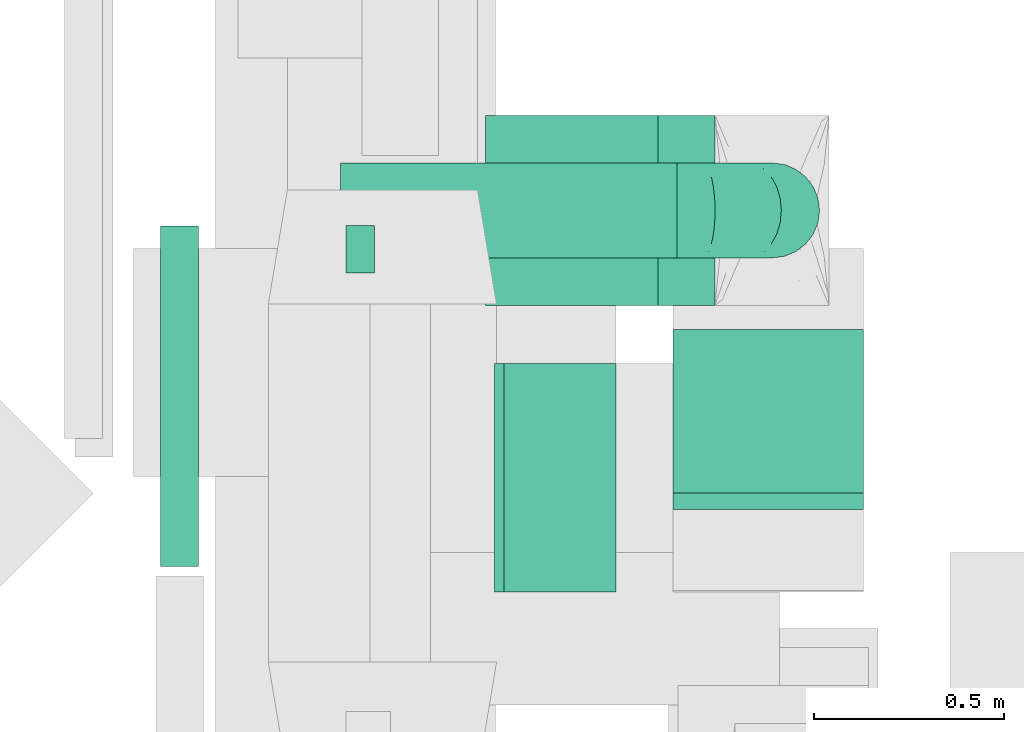
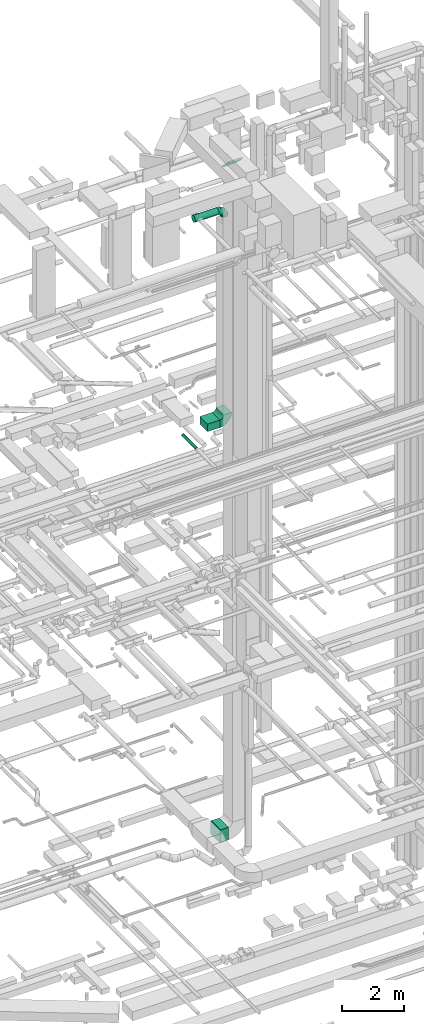
# One storey, part 133 of 337: 6 flow segments, 3 flow fittings.
"""IFC2X3 building model written with IfcOpenShell, lengths in millimetres."""

from ifc_helpers import new_model, entity, si_unit, converted_unit, derived_unit, direction, frame, frame_2d, origin, origin_2d_with_axis, place, context, subcontext, project, spatial, polyline, circle_curve, parameter, trimmed, segment, composite_curve, rectangle, circle, outline, extrude, faceted_brep, source, transform, mapped, material, type_object, type_shapes, element, save


model = new_model("IFC2X3")

# Units and contexts
model_context = context("Model", 3, precision=0.01, world=origin(), true_north=direction((6.12303176911189e-17, 1.0)))
body_context = subcontext(model_context, "Body", "Model", "MODEL_VIEW")
ifc_project = project(units=[si_unit("LENGTHUNIT", "METRE", prefix="MILLI"), si_unit("AREAUNIT", "SQUARE_METRE"), si_unit("VOLUMEUNIT", "CUBIC_METRE"), converted_unit("PLANEANGLEUNIT", "DEGREE", entity("IfcRatioMeasure", 0.0174532925199433), si_unit("PLANEANGLEUNIT", "RADIAN"), dimensions=[0, 0, 0, 0, 0, 0, 0]), si_unit("MASSUNIT", "GRAM", prefix="KILO"), derived_unit("MASSDENSITYUNIT", [(si_unit("MASSUNIT", "GRAM", prefix="KILO"), 1), (si_unit("LENGTHUNIT", "METRE"), -3)]), derived_unit("MOMENTOFINERTIAUNIT", [(si_unit("LENGTHUNIT", "METRE"), 4)]), si_unit("TIMEUNIT", "SECOND"), si_unit("FREQUENCYUNIT", "HERTZ"), si_unit("THERMODYNAMICTEMPERATUREUNIT", "DEGREE_CELSIUS"), derived_unit("THERMALTRANSMITTANCEUNIT", [(si_unit("MASSUNIT", "GRAM", prefix="KILO"), 1), (si_unit("THERMODYNAMICTEMPERATUREUNIT", "KELVIN"), -1), (si_unit("TIMEUNIT", "SECOND"), -3)]), derived_unit("VOLUMETRICFLOWRATEUNIT", [(si_unit("LENGTHUNIT", "METRE"), 3), (si_unit("TIMEUNIT", "SECOND"), -1)]), derived_unit("MASSFLOWRATEUNIT", [(si_unit("MASSUNIT", "GRAM", prefix="KILO"), 1), (si_unit("TIMEUNIT", "SECOND"), -1)]), derived_unit("ROTATIONALFREQUENCYUNIT", [(si_unit("TIMEUNIT", "SECOND"), -1)]), si_unit("ELECTRICCURRENTUNIT", "AMPERE"), si_unit("ELECTRICVOLTAGEUNIT", "VOLT"), si_unit("POWERUNIT", "WATT"), si_unit("FORCEUNIT", "NEWTON", prefix="KILO"), si_unit("ILLUMINANCEUNIT", "LUX"), si_unit("LUMINOUSFLUXUNIT", "LUMEN"), si_unit("LUMINOUSINTENSITYUNIT", "CANDELA"), derived_unit("USERDEFINED", [(si_unit("MASSUNIT", "GRAM", prefix="KILO"), -1), (si_unit("LENGTHUNIT", "METRE"), -2), (si_unit("TIMEUNIT", "SECOND"), 3), (si_unit("LUMINOUSFLUXUNIT", "LUMEN"), 1)]), derived_unit("LINEARVELOCITYUNIT", [(si_unit("LENGTHUNIT", "METRE"), 1), (si_unit("TIMEUNIT", "SECOND"), -1)]), si_unit("PRESSUREUNIT", "PASCAL"), derived_unit("USERDEFINED", [(si_unit("LENGTHUNIT", "METRE"), -2), (si_unit("MASSUNIT", "GRAM", prefix="KILO"), 1), (si_unit("TIMEUNIT", "SECOND"), -2)]), derived_unit("LINEARFORCEUNIT", [(si_unit("MASSUNIT", "GRAM", prefix="KILO"), 1), (si_unit("LENGTHUNIT", "METRE"), 1), (si_unit("TIMEUNIT", "SECOND"), -2), (si_unit("LENGTHUNIT", "METRE"), -1)]), derived_unit("PLANARFORCEUNIT", [(si_unit("MASSUNIT", "GRAM", prefix="KILO"), 1), (si_unit("LENGTHUNIT", "METRE"), 1), (si_unit("TIMEUNIT", "SECOND"), -2), (si_unit("LENGTHUNIT", "METRE"), -2)])], contexts=[model_context])

# Site, building, storey
site_placement = place(None, origin())
site = spatial("IfcSite", under=ifc_project, at=site_placement, CompositionType="ELEMENT")
building_placement = place(site_placement, origin())
building = spatial("IfcBuilding", under=site, at=building_placement, CompositionType="ELEMENT")
storey_placement = place(building_placement, origin())
storey = spatial("IfcBuildingStorey", under=building, at=storey_placement, CompositionType="ELEMENT", Elevation=0.0)

# Flow segments
duct_segment_type_1 = type_object("IfcDuctSegmentType", PredefinedType="NOTDEFINED")
flow_segment_1_placement = place(storey_placement, frame((23635.55, 11795.95, 3200.0)))
element("IfcFlowSegment", 1, at=flow_segment_1_placement, inside=storey, type_object=duct_segment_type_1, context=body_context, shape_type="SweptSolid", body=[
    extrude(rectangle(XDim=293.750000000011, YDim=600.0, at=origin_2d_with_axis()), frame((146.88, 300.0, 0.0)), (0.0, 0.0, 1.0), 500.0),
])
flow_segment_2_placement = place(storey_placement, frame((23586.61, 12547.9, 18950.0)))
element("IfcFlowSegment", 2, at=flow_segment_2_placement, inside=storey, type_object=duct_segment_type_1, context=body_context, shape_type="SweptSolid", body=[
    extrude(rectangle(XDim=452.500000000023, YDim=499.999999999999, at=origin_2d_with_axis()), frame((226.25, 250.0, 0.0)), (0.0, 0.0, 1.0), 300.000000000001),
])
duct_segment_type_2 = type_object("IfcDuctSegmentType", PredefinedType="NOTDEFINED")
flow_segment_3_placement = place(storey_placement, frame((22730.99, 11862.12, 18933.4)))
element("IfcFlowSegment", 3, at=flow_segment_3_placement, inside=storey, type_object=duct_segment_type_2, context=body_context, shape_type="SweptSolid", body=[
    extrude(circle(Radius=50.0, at=origin_2d_with_axis()), frame((51.6, 0.0, 51.6), z_axis=(0.0, 1.0, 0.0), x_axis=(1.0, 0.0, 0.0)), (0.0, 0.0, 1.0), 894.999999999996),
])
flow_segment_4_placement = place(storey_placement, frame((23219.15, 12631.59, 12973.4)))
element("IfcFlowSegment", 4, at=flow_segment_4_placement, inside=storey, type_object=duct_segment_type_2, context=body_context, shape_type="SweptSolid", body=[
    extrude(circle(Radius=62.5, at=origin_2d_with_axis()), frame((0.0, 64.1, 64.1), z_axis=(1.0, 0.0, 0.0), x_axis=(0.0, 1.0, 0.0)), (0.0, 0.0, 1.0), 75.0000000000089),
])
flow_segment_5_placement = place(storey_placement, frame((23204.92, 12671.3, 27193.4)))
element("IfcFlowSegment", 5, at=flow_segment_5_placement, inside=storey, type_object=duct_segment_type_2, context=body_context, shape_type="SweptSolid", body=[
    extrude(circle(Radius=125.0, at=origin_2d_with_axis()), frame((0.0, 126.6, 126.6), z_axis=(1.0, 0.0, 0.0), x_axis=(0.0, 1.0, 0.0)), (0.0, 0.0, 1.0), 884.19190363007),
])
duct_segment_type_3 = type_object("IfcDuctSegmentType", PredefinedType="NOTDEFINED")
flow_segment_6_placement = place(storey_placement, frame((24079.3, 12012.44, 29259.18)))
element("IfcFlowSegment", 6, at=flow_segment_6_placement, inside=storey, type_object=duct_segment_type_3, context=body_context, shape_type="SweptSolid", body=[
    extrude(rectangle(XDim=62.0342498214573, YDim=599.999999999998, at=origin_2d_with_axis()), frame((0.0, 236.5, 231.59), z_axis=(1.0, 0.0, 0.0), x_axis=(0.0, -0.697919351215837, -0.716176360401867)), (0.0, 0.0, 1.0), 500.000000000003),
])

# Flow fittings
ifc_material = material()
duct_fitting_type_1 = type_object("IfcDuctFittingType", PredefinedType="NOTDEFINED", material=ifc_material)
shared_shape_1 = source(origin(), body_context, "Body", "SweptSolid", [
    extrude(rectangle(XDim=26.0960000000053, YDim=600.0, at=origin_2d_with_axis()), frame((6.95, 0.0, -250.0)), (0.0, 0.0, 1.0), 500.0),
])
type_shapes(duct_fitting_type_1, [shared_shape_1])
flow_fitting_1_placement = place(storey_placement, frame((23615.55, 12095.95, 3450.0), z_axis=(0.0, 0.0, -1.0), x_axis=(1.0, 0.0, 0.0)))
element("IfcFlowFitting", 7, at=flow_fitting_1_placement, inside=storey, type_object=duct_fitting_type_1, material=ifc_material, context=body_context, shape_type="MappedRepresentation", body=[
    mapped(shared_shape_1, transform((0.0, 0.0, 0.0), scale=1.0)),
])
duct_fitting_type_2 = type_object("IfcDuctFittingType", PredefinedType="NOTDEFINED", material=ifc_material)
shared_shape_2 = source(origin(), body_context, "Body", "Brep", [
    faceted_brep([(-250.0, 0.0, -125.0), (-250.0, -32.35, -120.74), (-250.0, -62.5, -108.25), (-250.0, -88.39, -88.39), (-250.0, -108.25, -62.5), (-250.0, -120.74, -32.35), (-250.0, -125.0, 0.0), (-250.0, -120.74, 32.35), (-250.0, -108.25, 62.5), (-250.0, -88.39, 88.39), (-250.0, -62.5, 108.25), (-250.0, -32.35, 120.74), (-250.0, 0.0, 125.0), (-250.0, 32.35, 120.74), (-250.0, 62.5, 108.25), (-250.0, 88.39, 88.39), (-250.0, 108.25, 62.5), (-250.0, 120.74, 32.35), (-250.0, 125.0, 0.0), (-250.0, 120.74, -32.35), (-250.0, 108.25, -62.5), (-250.0, 88.39, -88.39), (-250.0, 62.5, -108.25), (-250.0, 32.35, -120.74), (-191.68, 32.35, 120.74), (-199.76, 62.5, 108.25), (-183.01, 0.0, 125.0), (-206.7, 88.39, 88.39), (-215.37, 120.74, 32.35), (-216.51, 125.0, 0.0), (-212.02, 108.25, 62.5), (-212.02, 108.25, -62.5), (-206.7, 88.39, -88.39), (-215.37, 120.74, -32.35), (-191.68, 32.35, -120.74), (-183.01, 0.0, -125.0), (-199.76, 62.5, -108.25), (-174.34, -32.35, -120.74), (-166.27, -62.5, -108.25), (-159.33, -88.39, -88.39), (-154.01, -108.25, -62.5), (-150.66, -120.74, -32.35), (-149.52, -125.0, 0.0), (-150.66, -120.74, 32.35), (-154.01, -108.25, 62.5), (-159.33, -88.39, 88.39), (-166.27, -62.5, 108.25), (-174.34, -32.35, 120.74), (-90.67, 90.67, 120.74), (-112.74, 112.74, 108.25), (-66.99, 66.99, 125.0), (-131.69, 131.69, 88.39), (-146.23, 146.23, 62.5), (-155.38, 155.38, 32.35), (-158.49, 158.49, 0.0), (-155.38, 155.38, -32.35), (-146.23, 146.23, -62.5), (-131.69, 131.69, -88.39), (-90.67, 90.67, -120.74), (-66.99, 66.99, -125.0), (-112.74, 112.74, -108.25), (-43.3, 43.3, -120.74), (-21.23, 21.23, -108.25), (-2.28, 2.28, -88.39), (12.26, -12.26, -62.5), (21.4, -21.4, -32.35), (24.52, -24.52, 0.0), (21.4, -21.4, 32.35), (12.26, -12.26, 62.5), (-2.28, 2.28, 88.39), (-21.23, 21.23, 108.25), (-43.3, 43.3, 120.74), (-32.35, 191.68, 120.74), (-62.5, 199.76, 108.25), (0.0, 183.01, 125.0), (-88.39, 206.7, 88.39), (-108.25, 212.02, 62.5), (-120.74, 215.37, 32.35), (-125.0, 216.51, 0.0), (-120.74, 215.37, -32.35), (-108.25, 212.02, -62.5), (-88.39, 206.7, -88.39), (-32.35, 191.68, -120.74), (0.0, 183.01, -125.0), (-62.5, 199.76, -108.25), (32.35, 174.34, -120.74), (62.5, 166.27, -108.25), (88.39, 159.33, -88.39), (108.25, 154.01, -62.5), (120.74, 150.66, -32.35), (125.0, 149.52, 0.0), (120.74, 150.66, 32.35), (108.25, 154.01, 62.5), (88.39, 159.33, 88.39), (62.5, 166.27, 108.25), (32.35, 174.34, 120.74), (-32.35, 250.0, -120.74), (-62.5, 250.0, -108.25), (-88.39, 250.0, -88.39), (-108.25, 250.0, -62.5), (-120.74, 250.0, -32.35), (-125.0, 250.0, 0.0), (-120.74, 250.0, 32.35), (-108.25, 250.0, 62.5), (-88.39, 250.0, 88.39), (-62.5, 250.0, 108.25), (-32.35, 250.0, 120.74), (0.0, 250.0, 125.0), (32.35, 250.0, 120.74), (62.5, 250.0, 108.25), (88.39, 250.0, 88.39), (108.25, 250.0, 62.5), (120.74, 250.0, 32.35), (125.0, 250.0, 0.0), (120.74, 250.0, -32.35), (108.25, 250.0, -62.5), (88.39, 250.0, -88.39), (62.5, 250.0, -108.25), (32.35, 250.0, -120.74), (0.0, 250.0, -125.0)], [[[0, 1, 2, 3, 4, 5, 6, 7, 8, 9, 10, 11, 12, 13, 14, 15, 16, 17, 18, 19, 20, 21, 22, 23]], [[24, 25, 14, 13]], [[26, 24, 13, 12]], [[14, 25, 27, 15]], [[28, 29, 18, 17]], [[30, 28, 17, 16]], [[15, 27, 30, 16]], [[20, 31, 32, 21]], [[33, 31, 20, 19]], [[18, 29, 33, 19]], [[34, 35, 0, 23]], [[36, 34, 23, 22]], [[21, 32, 36, 22]], [[1, 0, 35, 37]], [[2, 1, 37, 38]], [[38, 39, 3, 2]], [[5, 4, 40, 41]], [[6, 5, 41, 42]], [[39, 40, 4, 3]], [[6, 42, 43, 7]], [[7, 43, 44, 8]], [[8, 44, 45, 9]], [[9, 45, 46, 10]], [[10, 46, 47, 11]], [[26, 12, 11, 47]], [[48, 49, 25, 24]], [[50, 48, 24, 26]], [[27, 25, 49, 51]], [[52, 53, 28, 30]], [[51, 52, 30, 27]], [[29, 28, 53, 54]], [[55, 56, 31, 33]], [[54, 55, 33, 29]], [[32, 31, 56, 57]], [[58, 59, 35, 34]], [[60, 58, 34, 36]], [[57, 60, 36, 32]], [[37, 35, 59, 61]], [[38, 37, 61, 62]], [[39, 38, 62, 63]], [[41, 40, 64, 65]], [[42, 41, 65, 66]], [[63, 64, 40, 39]], [[43, 42, 66, 67]], [[44, 43, 67, 68]], [[68, 69, 45, 44]], [[46, 45, 69, 70]], [[47, 46, 70, 71]], [[26, 47, 71, 50]], [[72, 73, 49, 48]], [[74, 72, 48, 50]], [[51, 49, 73, 75]], [[76, 77, 53, 52]], [[75, 76, 52, 51]], [[54, 53, 77, 78]], [[79, 80, 56, 55]], [[78, 79, 55, 54]], [[57, 56, 80, 81]], [[82, 83, 59, 58]], [[84, 82, 58, 60]], [[81, 84, 60, 57]], [[61, 59, 83, 85]], [[62, 61, 85, 86]], [[63, 62, 86, 87]], [[65, 64, 88, 89]], [[66, 65, 89, 90]], [[87, 88, 64, 63]], [[67, 66, 90, 91]], [[68, 67, 91, 92]], [[92, 93, 69, 68]], [[70, 69, 93, 94]], [[71, 70, 94, 95]], [[50, 71, 95, 74]], [[96, 97, 98, 99, 100, 101, 102, 103, 104, 105, 106, 107, 108, 109, 110, 111, 112, 113, 114, 115, 116, 117, 118, 119]], [[72, 74, 107, 106]], [[73, 72, 106, 105]], [[75, 73, 105, 104]], [[77, 76, 103, 102]], [[78, 77, 102, 101]], [[75, 104, 103, 76]], [[78, 101, 100, 79]], [[79, 100, 99, 80]], [[80, 99, 98, 81]], [[84, 97, 96, 82]], [[82, 96, 119, 83]], [[84, 81, 98, 97]], [[83, 119, 118, 85]], [[85, 118, 117, 86]], [[116, 87, 86, 117]], [[88, 115, 114, 89]], [[89, 114, 113, 90]], [[115, 88, 87, 116]], [[91, 90, 113, 112]], [[92, 91, 112, 111]], [[111, 110, 93, 92]], [[95, 94, 109, 108]], [[74, 95, 108, 107]], [[110, 109, 94, 93]]]),
])
type_shapes(duct_fitting_type_2, [shared_shape_2])
flow_fitting_2_placement = place(storey_placement, frame((24339.11, 12797.9, 27320.0), z_axis=(0.0, -1.0, 0.0), x_axis=(0.0, 0.0, 1.0)))
element("IfcFlowFitting", 8, at=flow_fitting_2_placement, inside=storey, type_object=duct_fitting_type_2, material=ifc_material, context=body_context, shape_type="MappedRepresentation", body=[
    mapped(shared_shape_2, transform((0.0, 0.0, 0.0), scale=1.0)),
])
duct_fitting_type_3 = type_object("IfcDuctFittingType", PredefinedType="NOTDEFINED", material=ifc_material)
shared_shape_3 = source(origin(), body_context, "Body", "SweptSolid", [
    extrude(outline(composite_curve([segment(polyline([(-300.0, -150.0), (0.0, -150.0)]), True, "CONTINUOUS"), segment(trimmed(circle_curve(frame_2d((150.0, -150.0), x_axis=(0.0, 1.0)), 150.0), [parameter(0.0)], [parameter(90.0)], True, "PARAMETER"), False, "CONTINUOUS"), segment(polyline([(150.0, 0.0), (150.0, 300.0)]), True, "CONTINUOUS"), segment(trimmed(circle_curve(frame_2d((150.0, -150.0), x_axis=(0.0, 1.0)), 450.0), [parameter(0.0)], [parameter(90.0000000000001)], True, "PARAMETER"), True, "CONTINUOUS")], self_intersect=False)), frame((-150.0, 150.0, -250.0), z_axis=(0.0, 0.0, 1.0), x_axis=(-1.0, 0.0, 0.0)), (0.0, 0.0, 1.0), 500.0),
])
type_shapes(duct_fitting_type_3, [shared_shape_3])
flow_fitting_3_placement = place(storey_placement, frame((24339.11, 12797.9, 19100.0), z_axis=(0.0, -1.0, 0.0), x_axis=(1.0, 0.0, 0.0)))
element("IfcFlowFitting", 9, at=flow_fitting_3_placement, inside=storey, type_object=duct_fitting_type_3, material=ifc_material, context=body_context, shape_type="MappedRepresentation", body=[
    mapped(shared_shape_3, transform((0.0, 0.0, 0.0), scale=1.0)),
])

save(model, "model.ifc")
